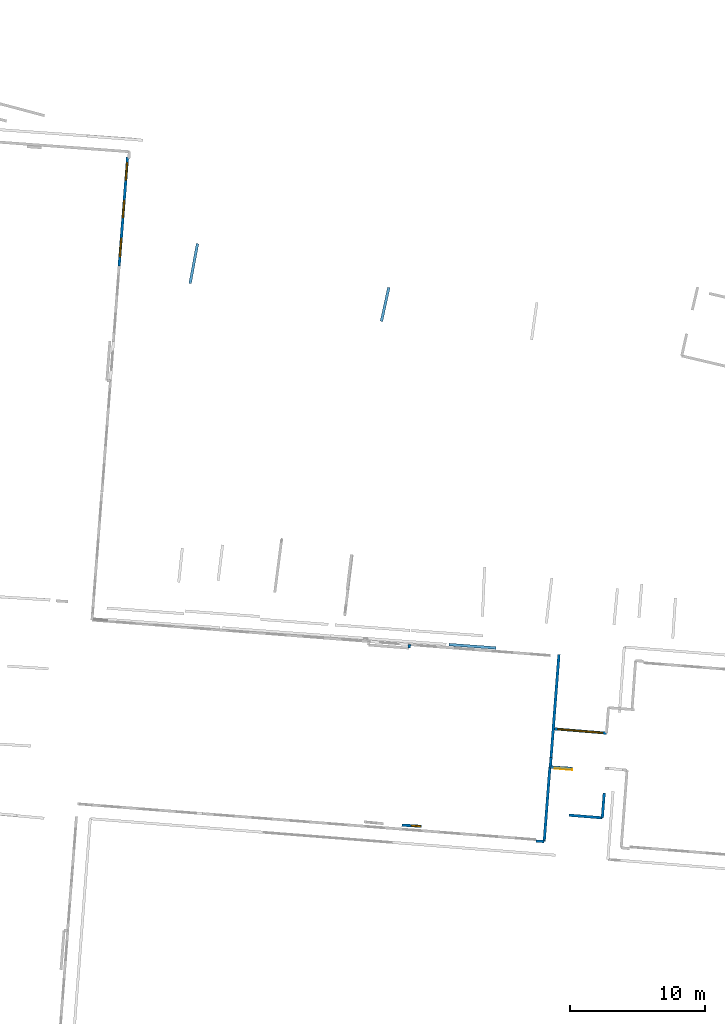
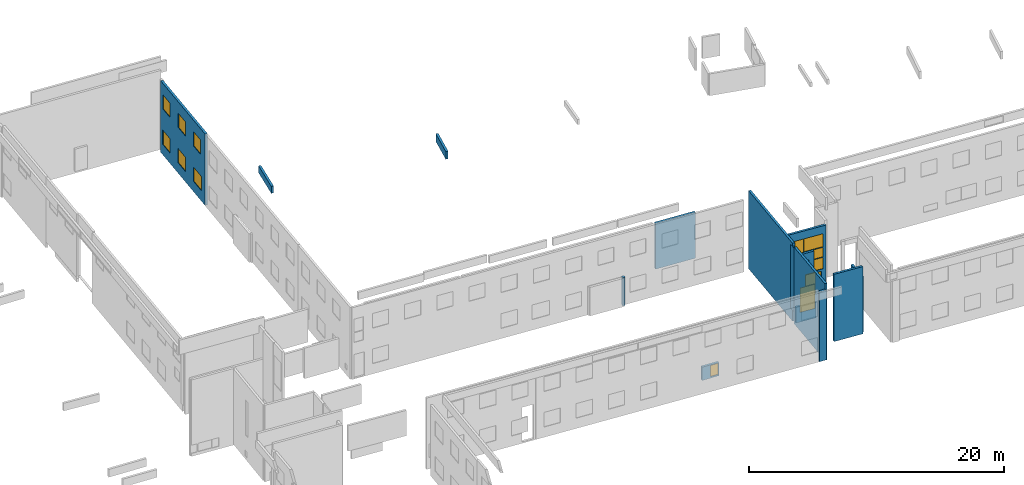
# One storey, part 15 of 27: 15 walls, 13 windows, 1 door, 15 openings.
"""IFC2X3 building model written with IfcOpenShell, lengths in metres."""

from ifc_helpers import new_model, entity, si_unit, converted_unit, derived_unit, direction, frame, frame_2d, origin, origin_2d_with_axis, place, context, subcontext, project, spatial, polyline, rectangle, outline, extrude, source, transform, mapped, material, layer, layer_set, layer_usage, type_object, type_shapes, element, fill, save


model = new_model("IFC2X3")

# Units and contexts
model_context = context("Model", 3, precision=1e-05, world=origin(), true_north=direction((0.0, 1.0)))
body_context = subcontext(model_context, "Body", "Model", "MODEL_VIEW")
ifc_project = project(units=[si_unit("LENGTHUNIT", "METRE"), si_unit("AREAUNIT", "SQUARE_METRE"), si_unit("VOLUMEUNIT", "CUBIC_METRE"), converted_unit("PLANEANGLEUNIT", "DEGREE", entity("IfcRatioMeasure", 0.0174532925199433), si_unit("PLANEANGLEUNIT", "RADIAN"), dimensions=[0, 0, 0, 0, 0, 0, 0]), si_unit("MASSUNIT", "GRAM", prefix="KILO"), derived_unit("MASSDENSITYUNIT", [(si_unit("MASSUNIT", "GRAM", prefix="KILO"), 1), (si_unit("LENGTHUNIT", "METRE"), -3)]), derived_unit("MOMENTOFINERTIAUNIT", [(si_unit("LENGTHUNIT", "METRE"), 4)]), si_unit("TIMEUNIT", "SECOND"), si_unit("FREQUENCYUNIT", "HERTZ"), si_unit("THERMODYNAMICTEMPERATUREUNIT", "DEGREE_CELSIUS"), derived_unit("THERMALTRANSMITTANCEUNIT", [(si_unit("MASSUNIT", "GRAM", prefix="KILO"), 1), (si_unit("THERMODYNAMICTEMPERATUREUNIT", "KELVIN"), -1), (si_unit("TIMEUNIT", "SECOND"), -3)]), derived_unit("VOLUMETRICFLOWRATEUNIT", [(si_unit("LENGTHUNIT", "METRE"), 3), (si_unit("TIMEUNIT", "SECOND"), -1)]), si_unit("ELECTRICCURRENTUNIT", "AMPERE"), si_unit("ELECTRICVOLTAGEUNIT", "VOLT"), si_unit("POWERUNIT", "WATT"), si_unit("FORCEUNIT", "NEWTON", prefix="KILO"), si_unit("ILLUMINANCEUNIT", "LUX"), si_unit("LUMINOUSFLUXUNIT", "LUMEN"), si_unit("LUMINOUSINTENSITYUNIT", "CANDELA"), derived_unit("USERDEFINED", [(si_unit("MASSUNIT", "GRAM", prefix="KILO"), -1), (si_unit("LENGTHUNIT", "METRE"), -2), (si_unit("TIMEUNIT", "SECOND"), 3), (si_unit("LUMINOUSFLUXUNIT", "LUMEN"), 1)]), derived_unit("LINEARVELOCITYUNIT", [(si_unit("LENGTHUNIT", "METRE"), 1), (si_unit("TIMEUNIT", "SECOND"), -1)]), si_unit("PRESSUREUNIT", "PASCAL"), derived_unit("USERDEFINED", [(si_unit("LENGTHUNIT", "METRE"), -2), (si_unit("MASSUNIT", "GRAM", prefix="KILO"), 1), (si_unit("TIMEUNIT", "SECOND"), -2)]), derived_unit("LINEARFORCEUNIT", [(si_unit("MASSUNIT", "GRAM", prefix="KILO"), 1), (si_unit("LENGTHUNIT", "METRE"), 1), (si_unit("TIMEUNIT", "SECOND"), -2), (si_unit("LENGTHUNIT", "METRE"), -1)]), derived_unit("PLANARFORCEUNIT", [(si_unit("MASSUNIT", "GRAM", prefix="KILO"), 1), (si_unit("LENGTHUNIT", "METRE"), 1), (si_unit("TIMEUNIT", "SECOND"), -2), (si_unit("LENGTHUNIT", "METRE"), -2)])], contexts=[model_context])

# Site, building, storey
placement_1 = place(None, origin())
site = spatial("IfcSite", under=ifc_project, at=placement_1, CompositionType="ELEMENT")
building = spatial("IfcBuilding", under=site, at=placement_1, CompositionType="ELEMENT")
storey_placement = place(placement_1, frame((0.0, 0.0, -61.043098449707)))
storey = spatial("IfcBuildingStorey", under=building, at=storey_placement, Name="level_-61.043098", CompositionType="ELEMENT", Elevation=-61.043098449707)

# Walls
ifc_material_1 = material(Name="Default wall")
ifc_layer = layer(ifc_material_1, 0.2)
ifc_layer_set = layer_set([ifc_layer], Name="wall_thickness_0.2000")
ifc_layer_usage = layer_usage(ifc_layer_set, "AXIS2", "POSITIVE", -0.1)
wall_type = type_object("IfcWallType", Name="wall_thickness_0.2000", PredefinedType="STANDARD", material=ifc_layer_set)
placement_2 = place(placement_1, frame((0.0, 0.0, -60.9578857421875)))
wall_1_placement = place(placement_2, frame((-37.0200372301927, -16.0524016754655, 0.0), z_axis=(0.0, 0.0, 1.0), x_axis=(-0.998600389394532, 0.0528891510717408, 0.0)))
element("IfcWallStandardCase", 1, at=wall_1_placement, inside=storey, type_object=wall_type, material=ifc_layer_usage, Name="Wall:152", ObjectType="Wall", context=body_context, shape_type="SweptSolid", body=[
    extrude(outline(polyline([(0.622197280445608, -0.1), (0.622197280445608, 0.1), (0.0, 0.1), (0.0, -0.1), (0.622197280445608, -0.1)])), origin(), (0.0, 0.0, 1.0), 6.67697906494141),
])
placement_3 = place(placement_1, frame((0.0, 0.0, -60.9578857421875)))
wall_2_placement = place(placement_3, frame((-63.2678405746218, 25.3179473888967, 0.0), z_axis=(0.0, 0.0, 1.0), x_axis=(0.183105225783561, 0.983093320235038, 0.0)))
element("IfcWallStandardCase", 2, at=wall_2_placement, inside=storey, type_object=wall_type, material=ifc_layer_usage, Name="Wall:195", ObjectType="Wall", context=body_context, shape_type="SweptSolid", body=[
    extrude(outline(polyline([(3.00025398109914, -0.1), (3.00025398109914, 0.1), (0.0, 0.1), (0.0, -0.1), (3.00025398109914, -0.1)])), origin(), (0.0, 0.0, 1.0), 0.661750793457031),
])
wall_3_placement = place(storey_placement, frame((-47.027272995632, -1.71549155766349, 0.0), z_axis=(0.0, 0.0, 1.0), x_axis=(0.0876257353755917, 0.996153467343204, 0.0)))
element("IfcWallStandardCase", 3, at=wall_3_placement, inside=storey, type_object=wall_type, material=ifc_layer_usage, Name="Wall:417", ObjectType="Wall", context=body_context, shape_type="SweptSolid", body=[
    extrude(outline(polyline([(0.26298879071159, -0.1), (0.26298879071159, 0.1), (0.0, 0.1), (0.0, -0.1), (0.26298879071159, -0.1)])), origin(), (0.0, 0.0, 1.0), 2.72571182250977),
])
placement_4 = place(placement_1, frame((0.0, 0.0, -59.9867630004883)))
wall_4_placement = place(placement_4, frame((-36.5148844694939, -9.81366283017277, 0.0), z_axis=(0.0, 0.0, 1.0), x_axis=(-0.0738247869205139, -0.997271227317895, 0.0)))
element("IfcWallStandardCase", 4, at=wall_4_placement, inside=storey, type_object=wall_type, material=ifc_layer_usage, Name="Wall:574", ObjectType="Wall", context=body_context, shape_type="SweptSolid", body=[
    extrude(outline(polyline([(0.717573367123586, -0.1), (0.717573367123586, 0.1), (0.0, 0.1), (0.0, -0.1), (0.717573367123586, -0.1)])), origin(), (0.0, 0.0, 1.0), 6.1148567199707),
])
placement_5 = place(placement_1, frame((0.0, 0.0, -60.9578857421875)))
wall_5_placement = place(placement_5, frame((-32.5704525703659, -12.4499416985043, 0.0), z_axis=(0.0, 0.0, 1.0), x_axis=(-0.0771292254040907, -0.997021104384739, 0.0)))
element("IfcWallStandardCase", 5, at=wall_5_placement, inside=storey, type_object=wall_type, material=ifc_layer_usage, Name="Wall:581", ObjectType="Wall", context=body_context, shape_type="SweptSolid", body=[
    extrude(outline(polyline([(1.85330962665053, -0.1), (1.85330962665053, 0.1), (0.0, 0.1), (0.0, -0.1), (1.85330962665053, -0.1)])), origin(), (0.0, 0.0, 1.0), 5.34588623046875),
])

# Wall, opening, window
placement_6 = place(placement_1, frame((0.0, 0.0, -59.9867630004883)))
wall_6_placement = place(placement_6, frame((-46.120380331813, -14.9260019400806, 0.0), z_axis=(0.0, 0.0, 1.0), x_axis=(-0.998140237205835, 0.0609595511030088, 0.0)))
wall_6 = element("IfcWallStandardCase", 6, at=wall_6_placement, inside=storey, type_object=wall_type, material=ifc_layer_usage, Name="Wall:673", ObjectType="Wall", context=body_context, shape_type="SweptSolid", body=[
    extrude(outline(polyline([(1.45858802446844, -0.1), (1.45858802446844, 0.1), (0.0, 0.1), (0.0, -0.1), (1.45858802446844, -0.1)])), origin(), (0.0, 0.0, 1.0), 1.27852630615234),
])
opening_1_placement = place(wall_6_placement, frame((0.0500006700359802, -0.1, 0.138454437255859)))
opening_1 = element("IfcOpeningElement", 7, at=opening_1_placement, cuts=wall_6, Name="Opening : 700 x 1075 : 70", ObjectType="Opening", context=body_context, shape_type="SweptSolid", body=[
    extrude(rectangle(XDim=0.7, YDim=1.075, at=frame_2d((0.5375, 0.35), x_axis=(0.0, 1.0))), frame((0.0, 0.0, 0.0), z_axis=(0.0, 1.0, 0.0), x_axis=(0.0, 0.0, 1.0)), (0.0, 0.0, 1.0), 0.2),
])
ifc_material_2 = material(Name="Window Default")
window_style_1 = type_object("IfcWindowStyle", Name="Window : 700 x 1075mm", ConstructionType="NOTDEFINED", OperationType="NOTDEFINED", ParameterTakesPrecedence=False, Sizeable=False, material=ifc_material_2)
shared_shape_1 = source(origin(), body_context, "Body", "SweptSolid", [
    extrude(rectangle(XDim=0.1, YDim=0.7, at=origin_2d_with_axis()), frame((0.35, 0.1, 0.0), z_axis=(0.0, 0.0, 1.0), x_axis=(0.0, 1.0, 0.0)), (0.0, 0.0, 1.0), 1.075),
])
type_shapes(window_style_1, [shared_shape_1])
window_1_placement = place(opening_1_placement, origin())
window_1 = element("IfcWindow", 8, at=window_1_placement, inside=storey, type_object=window_style_1, Name="Window : 700 x 1075mm : 62", ObjectType="Window : 700 x 1075mm", OverallHeight=1.075, OverallWidth=0.7, context=body_context, shape_type="MappedRepresentation", body=[
    mapped(shared_shape_1, transform((0.0, 0.0, 0.0), scale=1.0)),
])
fill(opening_1, window_1)

# Walls
wall_7_placement = place(storey_placement, frame((-32.7133952443243, -14.2977281924001, 0.0), z_axis=(0.0, 0.0, 1.0), x_axis=(-0.996860150969085, 0.0791823175329724, 0.0)))
element("IfcWallStandardCase", 9, at=wall_7_placement, inside=storey, type_object=wall_type, material=ifc_layer_usage, Name="Wall:1039", ObjectType="Wall", context=body_context, shape_type="SweptSolid", body=[
    extrude(outline(polyline([(2.48715269829612, -0.1), (2.48715269829612, 0.1), (0.0, 0.1), (0.0, -0.1), (2.48715269829612, -0.1)])), origin(), (0.0, 0.0, 1.0), 6.44229888916016),
])
wall_8_placement = place(storey_placement, frame((-36.5989793655519, -10.5185171790629, 0.0), z_axis=(0.0, 0.0, 1.0), x_axis=(-0.0758680967857905, -0.997117862587017, 0.0)))
element("IfcWallStandardCase", 10, at=wall_8_placement, inside=storey, type_object=wall_type, material=ifc_layer_usage, Name="Wall:1173", ObjectType="Wall", context=body_context, shape_type="SweptSolid", body=[
    extrude(outline(polyline([(5.54987765112908, -0.1), (5.54987765112908, 0.1), (0.0, 0.1), (0.0, -0.1), (5.54987765112908, -0.1)])), origin(), (0.0, 0.0, 1.0), 7.32660675048828),
])

# Wall, opening, door
placement_7 = place(placement_1, frame((0.0, 0.0, -60.9578857421875)))
wall_9_placement = place(placement_7, frame((-34.8802351490061, -10.6662097816332, 0.0), z_axis=(0.0, 0.0, 1.0), x_axis=(-0.9963282509121, 0.0856155151502107, 0.0)))
wall_9 = element("IfcWallStandardCase", 11, at=wall_9_placement, inside=storey, type_object=wall_type, material=ifc_layer_usage, Name="Wall:1256", ObjectType="Wall", context=body_context, shape_type="SweptSolid", body=[
    extrude(outline(polyline([(1.72508024712668, -0.1), (1.72508024712668, 0.1), (0.0, 0.1), (0.0, -0.1), (1.72508024712668, -0.1)])), origin(), (0.0, 0.0, 1.0), 1.51040649414062),
])
opening_2_placement = place(wall_9_placement, frame((0.059996572224372, -0.1, 0.928901672363281)))
opening_2 = element("IfcOpeningElement", 12, at=opening_2_placement, cuts=wall_9, Name="Opening : 1290 x 2325 : 172", ObjectType="Opening", context=body_context, shape_type="SweptSolid", body=[
    extrude(rectangle(XDim=1.29, YDim=2.325, at=frame_2d((1.1625, 0.645), x_axis=(0.0, 1.0))), frame((0.0, 0.0, 0.0), z_axis=(0.0, 1.0, 0.0), x_axis=(0.0, 0.0, 1.0)), (0.0, 0.0, 1.0), 0.2),
])
ifc_material_3 = material(Name="Door Panel")
door_style = type_object("IfcDoorStyle", Name="Door : 1290 x 2325mm", ConstructionType="NOTDEFINED", OperationType="SINGLE_SWING_RIGHT", ParameterTakesPrecedence=False, Sizeable=False, material=ifc_material_3)
shared_shape_2 = source(origin(), body_context, "Body", "SweptSolid", [
    extrude(rectangle(XDim=0.05, YDim=1.29, at=origin_2d_with_axis()), frame((0.645, 0.175, 0.0), z_axis=(0.0, 0.0, 1.0), x_axis=(0.0, 1.0, 0.0)), (0.0, 0.0, 1.0), 2.325),
])
type_shapes(door_style, [shared_shape_2])
door_placement = place(opening_2_placement, origin())
door = element("IfcDoor", 13, at=door_placement, inside=storey, type_object=door_style, Name="Door : 1290 x 2325mm : 6", ObjectType="Door : 1290 x 2325mm", OverallHeight=2.325, OverallWidth=1.29, context=body_context, shape_type="MappedRepresentation", body=[
    mapped(shared_shape_2, transform((0.0, 0.0, 0.0), scale=1.0)),
])
fill(opening_2, door)

# Wall, openings, windows
wall_10_placement = place(storey_placement, frame((-32.4030801710621, -8.02005382141887, 0.0), z_axis=(0.0, 0.0, 1.0), x_axis=(-0.996609152140908, 0.0822812121263409, 0.0)))
wall_10 = element("IfcWallStandardCase", 14, at=wall_10_placement, inside=storey, type_object=wall_type, material=ifc_layer_usage, Name="Wall:1337", ObjectType="Wall", context=body_context, shape_type="SweptSolid", body=[
    extrude(outline(polyline([(3.95944026383871, -0.1), (3.95944026383871, 0.1), (0.0, 0.1), (0.0, -0.1), (3.95944026383871, -0.1)])), origin(), (0.0, 0.0, 1.0), 6.5118293762207),
])
opening_3_placement = place(wall_10_placement, frame((0.274046374124539, -0.1, 4.48965454101562)))
opening_3 = element("IfcOpeningElement", 15, at=opening_3_placement, cuts=wall_10, Name="Opening : 1650 x 1265 : 203", ObjectType="Opening", context=body_context, shape_type="SweptSolid", body=[
    extrude(rectangle(XDim=1.65, YDim=1.265, at=frame_2d((0.6325, 0.825), x_axis=(0.0, 1.0))), frame((0.0, 0.0, 0.0), z_axis=(0.0, 1.0, 0.0), x_axis=(0.0, 0.0, 1.0)), (0.0, 0.0, 1.0), 0.2),
])
opening_4_placement = place(wall_10_placement, frame((1.96404582123105, -0.1, 2.38465118408203)))
opening_4 = element("IfcOpeningElement", 16, at=opening_4_placement, cuts=wall_10, Name="Opening : 1655 x 3370 : 204", ObjectType="Opening", context=body_context, shape_type="SweptSolid", body=[
    extrude(rectangle(XDim=1.655, YDim=3.37, at=frame_2d((1.685, 0.8275), x_axis=(0.0, 1.0))), frame((0.0, 0.0, 0.0), z_axis=(0.0, 1.0, 0.0), x_axis=(0.0, 0.0, 1.0)), (0.0, 0.0, 1.0), 0.2),
])
opening_5_placement = place(wall_10_placement, frame((0.274046374124539, -0.1, 3.5196533203125)))
opening_5 = element("IfcOpeningElement", 17, at=opening_5_placement, cuts=wall_10, Name="Opening : 1645 x 935 : 205", ObjectType="Opening", context=body_context, shape_type="SweptSolid", body=[
    extrude(rectangle(XDim=1.645, YDim=0.935, at=frame_2d((0.4675, 0.8225), x_axis=(0.0, 1.0))), frame((0.0, 0.0, 0.0), z_axis=(0.0, 1.0, 0.0), x_axis=(0.0, 0.0, 1.0)), (0.0, 0.0, 1.0), 0.2),
])
opening_6_placement = place(wall_10_placement, frame((0.269047373866643, -0.1, 2.3946533203125)))
opening_6 = element("IfcOpeningElement", 18, at=opening_6_placement, cuts=wall_10, Name="Opening : 1650 x 1100 : 206", ObjectType="Opening", context=body_context, shape_type="SweptSolid", body=[
    extrude(rectangle(XDim=1.65, YDim=1.1, at=frame_2d((0.55, 0.825), x_axis=(0.0, 1.0))), frame((0.0, 0.0, 0.0), z_axis=(0.0, 1.0, 0.0), x_axis=(0.0, 0.0, 1.0)), (0.0, 0.0, 1.0), 0.2),
])
opening_7_placement = place(wall_10_placement, frame((0.424045305038958, -0.1, 0.164653778076172)))
opening_7 = element("IfcOpeningElement", 19, at=opening_7_placement, cuts=wall_10, Name="Opening : 340 x 2040 : 207", ObjectType="Opening", context=body_context, shape_type="SweptSolid", body=[
    extrude(rectangle(XDim=0.34, YDim=2.04, at=frame_2d((1.02, 0.17), x_axis=(0.0, 1.0))), frame((0.0, 0.0, 0.0), z_axis=(0.0, 1.0, 0.0), x_axis=(0.0, 0.0, 1.0)), (0.0, 0.0, 1.0), 0.2),
])
opening_8_placement = place(wall_10_placement, frame((0.89904462412663, -0.1, 0.159652709960938)))
opening_8 = element("IfcOpeningElement", 20, at=opening_8_placement, cuts=wall_10, Name="Opening : 875 x 2045 : 208", ObjectType="Opening", context=body_context, shape_type="SweptSolid", body=[
    extrude(rectangle(XDim=0.875, YDim=2.045, at=frame_2d((1.0225, 0.4375), x_axis=(0.0, 1.0))), frame((0.0, 0.0, 0.0), z_axis=(0.0, 1.0, 0.0), x_axis=(0.0, 0.0, 1.0)), (0.0, 0.0, 1.0), 0.2),
])
window_style_2 = type_object("IfcWindowStyle", Name="Window : 1650 x 1265mm", ConstructionType="NOTDEFINED", OperationType="NOTDEFINED", ParameterTakesPrecedence=False, Sizeable=False, material=ifc_material_2)
shared_shape_3 = source(origin(), body_context, "Body", "SweptSolid", [
    extrude(rectangle(XDim=0.1, YDim=1.65, at=origin_2d_with_axis()), frame((0.825, 0.1, 0.0), z_axis=(0.0, 0.0, 1.0), x_axis=(0.0, 1.0, 0.0)), (0.0, 0.0, 1.0), 1.265),
])
type_shapes(window_style_2, [shared_shape_3])
window_2_placement = place(opening_3_placement, origin())
window_2 = element("IfcWindow", 21, at=window_2_placement, inside=storey, type_object=window_style_2, Name="Window : 1650 x 1265mm : 186", ObjectType="Window : 1650 x 1265mm", OverallHeight=1.265, OverallWidth=1.65, context=body_context, shape_type="MappedRepresentation", body=[
    mapped(shared_shape_3, transform((0.0, 0.0, 0.0), scale=1.0)),
])
fill(opening_3, window_2)
window_style_3 = type_object("IfcWindowStyle", Name="Window : 1655 x 3370mm", ConstructionType="NOTDEFINED", OperationType="NOTDEFINED", ParameterTakesPrecedence=False, Sizeable=False, material=ifc_material_2)
shared_shape_4 = source(origin(), body_context, "Body", "SweptSolid", [
    extrude(rectangle(XDim=0.1, YDim=1.655, at=origin_2d_with_axis()), frame((0.8275, 0.1, 0.0), z_axis=(0.0, 0.0, 1.0), x_axis=(0.0, 1.0, 0.0)), (0.0, 0.0, 1.0), 3.37),
])
type_shapes(window_style_3, [shared_shape_4])
window_3_placement = place(opening_4_placement, origin())
window_3 = element("IfcWindow", 22, at=window_3_placement, inside=storey, type_object=window_style_3, Name="Window : 1655 x 3370mm : 187", ObjectType="Window : 1655 x 3370mm", OverallHeight=3.37, OverallWidth=1.655, context=body_context, shape_type="MappedRepresentation", body=[
    mapped(shared_shape_4, transform((0.0, 0.0, 0.0), scale=1.0)),
])
fill(opening_4, window_3)
window_style_4 = type_object("IfcWindowStyle", Name="Window : 1645 x 935mm", ConstructionType="NOTDEFINED", OperationType="NOTDEFINED", ParameterTakesPrecedence=False, Sizeable=False, material=ifc_material_2)
shared_shape_5 = source(origin(), body_context, "Body", "SweptSolid", [
    extrude(rectangle(XDim=0.1, YDim=1.645, at=origin_2d_with_axis()), frame((0.8225, 0.1, 0.0), z_axis=(0.0, 0.0, 1.0), x_axis=(0.0, 1.0, 0.0)), (0.0, 0.0, 1.0), 0.935),
])
type_shapes(window_style_4, [shared_shape_5])
window_4_placement = place(opening_5_placement, origin())
window_4 = element("IfcWindow", 23, at=window_4_placement, inside=storey, type_object=window_style_4, Name="Window : 1645 x 935mm : 188", ObjectType="Window : 1645 x 935mm", OverallHeight=0.935, OverallWidth=1.645, context=body_context, shape_type="MappedRepresentation", body=[
    mapped(shared_shape_5, transform((0.0, 0.0, 0.0), scale=1.0)),
])
fill(opening_5, window_4)
window_style_5 = type_object("IfcWindowStyle", Name="Window : 1650 x 1100mm", ConstructionType="NOTDEFINED", OperationType="NOTDEFINED", ParameterTakesPrecedence=False, Sizeable=False, material=ifc_material_2)
shared_shape_6 = source(origin(), body_context, "Body", "SweptSolid", [
    extrude(rectangle(XDim=0.1, YDim=1.65, at=origin_2d_with_axis()), frame((0.825, 0.1, 0.0), z_axis=(0.0, 0.0, 1.0), x_axis=(0.0, 1.0, 0.0)), (0.0, 0.0, 1.0), 1.1),
])
type_shapes(window_style_5, [shared_shape_6])
window_5_placement = place(opening_6_placement, origin())
window_5 = element("IfcWindow", 24, at=window_5_placement, inside=storey, type_object=window_style_5, Name="Window : 1650 x 1100mm : 189", ObjectType="Window : 1650 x 1100mm", OverallHeight=1.1, OverallWidth=1.65, context=body_context, shape_type="MappedRepresentation", body=[
    mapped(shared_shape_6, transform((0.0, 0.0, 0.0), scale=1.0)),
])
fill(opening_6, window_5)
window_style_6 = type_object("IfcWindowStyle", Name="Window : 340 x 2040mm", ConstructionType="NOTDEFINED", OperationType="NOTDEFINED", ParameterTakesPrecedence=False, Sizeable=False, material=ifc_material_2)
shared_shape_7 = source(origin(), body_context, "Body", "SweptSolid", [
    extrude(rectangle(XDim=0.1, YDim=0.34, at=origin_2d_with_axis()), frame((0.17, 0.1, 0.0), z_axis=(0.0, 0.0, 1.0), x_axis=(0.0, 1.0, 0.0)), (0.0, 0.0, 1.0), 2.04),
])
type_shapes(window_style_6, [shared_shape_7])
window_6_placement = place(opening_7_placement, origin())
window_6 = element("IfcWindow", 25, at=window_6_placement, inside=storey, type_object=window_style_6, Name="Window : 340 x 2040mm : 190", ObjectType="Window : 340 x 2040mm", OverallHeight=2.04, OverallWidth=0.34, context=body_context, shape_type="MappedRepresentation", body=[
    mapped(shared_shape_7, transform((0.0, 0.0, 0.0), scale=1.0)),
])
fill(opening_7, window_6)
window_style_7 = type_object("IfcWindowStyle", Name="Window : 875 x 2045mm", ConstructionType="NOTDEFINED", OperationType="NOTDEFINED", ParameterTakesPrecedence=False, Sizeable=False, material=ifc_material_2)
shared_shape_8 = source(origin(), body_context, "Body", "SweptSolid", [
    extrude(rectangle(XDim=0.1, YDim=0.875, at=origin_2d_with_axis()), frame((0.4375, 0.1, 0.0), z_axis=(0.0, 0.0, 1.0), x_axis=(0.0, 1.0, 0.0)), (0.0, 0.0, 1.0), 2.045),
])
type_shapes(window_style_7, [shared_shape_8])
window_7_placement = place(opening_8_placement, origin())
window_7 = element("IfcWindow", 26, at=window_7_placement, inside=storey, type_object=window_style_7, Name="Window : 875 x 2045mm : 191", ObjectType="Window : 875 x 2045mm", OverallHeight=2.045, OverallWidth=0.875, context=body_context, shape_type="MappedRepresentation", body=[
    mapped(shared_shape_8, transform((0.0, 0.0, 0.0), scale=1.0)),
])
fill(opening_8, window_7)

# Walls
placement_8 = place(placement_1, frame((0.0, 0.0, -58.6692237854004)))
wall_11_placement = place(placement_8, frame((-44.0704143280616, -1.45279970064969, 0.0), z_axis=(0.0, 0.0, 1.0), x_axis=(0.997320641977179, -0.0731542007421811, 0.0)))
element("IfcWallStandardCase", 27, at=wall_11_placement, inside=storey, type_object=wall_type, material=ifc_layer_usage, Name="Wall:1430", ObjectType="Wall", context=body_context, shape_type="SweptSolid", body=[
    extrude(outline(polyline([(3.47500138563488, -0.1), (3.47500138563488, 0.1), (0.0, 0.1), (0.0, -0.1), (3.47500138563488, -0.1)])), origin(), (0.0, 0.0, 1.0), 4.3883171081543),
])
wall_12_placement = place(storey_placement, frame((-35.9275419658002, -2.20070825959961, 0.0), z_axis=(0.0, 0.0, 1.0), x_axis=(-0.0765101996187178, -0.997068798706641, 0.0)))
element("IfcWallStandardCase", 28, at=wall_12_placement, inside=storey, type_object=wall_type, material=ifc_layer_usage, Name="Wall:1591", ObjectType="Wall", context=body_context, shape_type="SweptSolid", body=[
    extrude(outline(polyline([(7.97539383834117, -0.1), (7.97539383834117, 0.1), (0.0, 0.1), (0.0, -0.1), (7.97539383834117, -0.1)])), origin(), (0.0, 0.0, 1.0), 7.4647102355957),
])
placement_9 = place(placement_1, frame((0.0, 0.0, -60.9578857421875)))
wall_13_placement = place(placement_9, frame((-49.0848434467702, 22.5056424875311, 0.0), z_axis=(0.0, 0.0, 1.0), x_axis=(0.212129806137661, 0.977241497966597, 0.0)))
element("IfcWallStandardCase", 29, at=wall_13_placement, inside=storey, type_object=wall_type, material=ifc_layer_usage, Name="Wall:1684", ObjectType="Wall", context=body_context, shape_type="SweptSolid", body=[
    extrude(outline(polyline([(2.57000020386452, -0.1), (2.57000020386452, 0.1), (0.0, 0.1), (0.0, -0.1), (2.57000020386452, -0.1)])), origin(), (0.0, 0.0, 1.0), 0.739894866943359),
])

# Wall, opening
placement_10 = place(placement_1, frame((0.0, 0.0, -59.5395584106445)))
wall_14_placement = place(placement_10, frame((-35.0101656493806, -10.6263727979115, 0.0), z_axis=(0.0, 0.0, 1.0), x_axis=(-0.998062938165299, 0.0622123095604904, 0.0)))
wall_14 = element("IfcWallStandardCase", 30, at=wall_14_placement, inside=storey, type_object=wall_type, material=ifc_layer_usage, Name="Wall:1846", ObjectType="Wall", context=body_context, shape_type="SweptSolid", body=[
    extrude(outline(polyline([(1.59256625306782, -0.1), (1.59256625306782, 0.1), (0.0, 0.1), (0.0, -0.1), (1.59256625306782, -0.1)])), origin(), (0.0, 0.0, 1.0), 5.0082893371582),
])
opening_9_placement = place(wall_14_placement, frame((0.429997760462984, -0.1, 0.0532913208007812)))
element("IfcOpeningElement", 31, at=opening_9_placement, cuts=wall_14, Name="Opening : 805 x 4245 : 284", ObjectType="Opening", context=body_context, shape_type="SweptSolid", body=[
    extrude(rectangle(XDim=0.805, YDim=4.245, at=frame_2d((2.1225, 0.4025), x_axis=(0.0, 1.0))), frame((0.0, 0.0, 0.0), z_axis=(0.0, 1.0, 0.0), x_axis=(0.0, 0.0, 1.0)), (0.0, 0.0, 1.0), 0.2),
])

# Wall, openings, windows
wall_15_placement = place(storey_placement, frame((-67.9032874621412, 34.6705275496588, 0.0), z_axis=(0.0, 0.0, 1.0), x_axis=(-0.0775823258634108, -0.996985949105414, 0.0)))
wall_15 = element("IfcWallStandardCase", 32, at=wall_15_placement, inside=storey, type_object=wall_type, material=ifc_layer_usage, Name="Wall:1871", ObjectType="Wall", context=body_context, shape_type="SweptSolid", body=[
    extrude(outline(polyline([(8.0949992493728, -0.1), (8.0949992493728, 0.1), (0.0, 0.1), (0.0, -0.1), (8.0949992493728, -0.1)])), origin(), (0.0, 0.0, 1.0), 6.83392333984375),
])
opening_10_placement = place(wall_15_placement, frame((3.21000007047297, -0.1, 4.38211059570312)))
opening_10 = element("IfcOpeningElement", 33, at=opening_10_placement, cuts=wall_15, Name="Opening : 1300 x 1365 : 285", ObjectType="Opening", context=body_context, shape_type="SweptSolid", body=[
    extrude(rectangle(XDim=1.3, YDim=1.365, at=frame_2d((0.6825, 0.65), x_axis=(0.0, 1.0))), frame((0.0, 0.0, 0.0), z_axis=(0.0, 1.0, 0.0), x_axis=(0.0, 0.0, 1.0)), (0.0, 0.0, 1.0), 0.2),
])
opening_11_placement = place(wall_15_placement, frame((0.40500234076263, -0.1, 4.39210891723633)))
opening_11 = element("IfcOpeningElement", 34, at=opening_11_placement, cuts=wall_15, Name="Opening : 1300 x 1365 : 286", ObjectType="Opening", context=body_context, shape_type="SweptSolid", body=[
    extrude(rectangle(XDim=1.3, YDim=1.365, at=frame_2d((0.6825, 0.65), x_axis=(0.0, 1.0))), frame((0.0, 0.0, 0.0), z_axis=(0.0, 1.0, 0.0), x_axis=(0.0, 0.0, 1.0)), (0.0, 0.0, 1.0), 0.2),
])
opening_12_placement = place(wall_15_placement, frame((6.0100000424188, -0.1, 4.36711120605469)))
opening_12 = element("IfcOpeningElement", 35, at=opening_12_placement, cuts=wall_15, Name="Opening : 1295 x 1380 : 287", ObjectType="Opening", context=body_context, shape_type="SweptSolid", body=[
    extrude(rectangle(XDim=1.295, YDim=1.38, at=frame_2d((0.69, 0.6475), x_axis=(0.0, 1.0))), frame((0.0, 0.0, 0.0), z_axis=(0.0, 1.0, 0.0), x_axis=(0.0, 0.0, 1.0)), (0.0, 0.0, 1.0), 0.2),
])
opening_13_placement = place(wall_15_placement, frame((0.389999433588876, -0.1, 0.982109069824219)))
opening_13 = element("IfcOpeningElement", 36, at=opening_13_placement, cuts=wall_15, Name="Opening : 1305 x 1370 : 288", ObjectType="Opening", context=body_context, shape_type="SweptSolid", body=[
    extrude(rectangle(XDim=1.305, YDim=1.37, at=frame_2d((0.685, 0.6525), x_axis=(0.0, 1.0))), frame((0.0, 0.0, 0.0), z_axis=(0.0, 1.0, 0.0), x_axis=(0.0, 0.0, 1.0)), (0.0, 0.0, 1.0), 0.2),
])
opening_14_placement = place(wall_15_placement, frame((3.20000003395692, -0.1, 0.987110137939453)))
opening_14 = element("IfcOpeningElement", 37, at=opening_14_placement, cuts=wall_15, Name="Opening : 1305 x 1365 : 289", ObjectType="Opening", context=body_context, shape_type="SweptSolid", body=[
    extrude(rectangle(XDim=1.305, YDim=1.365, at=frame_2d((0.6825, 0.6525), x_axis=(0.0, 1.0))), frame((0.0, 0.0, 0.0), z_axis=(0.0, 1.0, 0.0), x_axis=(0.0, 0.0, 1.0)), (0.0, 0.0, 1.0), 0.2),
])
opening_15_placement = place(wall_15_placement, frame((6.0100000424188, -0.1, 0.982109069824219)))
opening_15 = element("IfcOpeningElement", 38, at=opening_15_placement, cuts=wall_15, Name="Opening : 1405 x 1365 : 290", ObjectType="Opening", context=body_context, shape_type="SweptSolid", body=[
    extrude(rectangle(XDim=1.405, YDim=1.365, at=frame_2d((0.6825, 0.7025), x_axis=(0.0, 1.0))), frame((0.0, 0.0, 0.0), z_axis=(0.0, 1.0, 0.0), x_axis=(0.0, 0.0, 1.0)), (0.0, 0.0, 1.0), 0.2),
])
window_style_8 = type_object("IfcWindowStyle", Name="Window : 1405 x 1365mm", ConstructionType="NOTDEFINED", OperationType="NOTDEFINED", ParameterTakesPrecedence=False, Sizeable=False, material=ifc_material_2)
shared_shape_9 = source(origin(), body_context, "Body", "SweptSolid", [
    extrude(rectangle(XDim=0.1, YDim=1.405, at=origin_2d_with_axis()), frame((0.7025, 0.1, 0.0), z_axis=(0.0, 0.0, 1.0), x_axis=(0.0, 1.0, 0.0)), (0.0, 0.0, 1.0), 1.365),
])
type_shapes(window_style_8, [shared_shape_9])
window_8_placement = place(opening_15_placement, origin())
window_8 = element("IfcWindow", 39, at=window_8_placement, inside=storey, type_object=window_style_8, Name="Window : 1405 x 1365mm : 271", ObjectType="Window : 1405 x 1365mm", OverallHeight=1.365, OverallWidth=1.405, context=body_context, shape_type="MappedRepresentation", body=[
    mapped(shared_shape_9, transform((0.0, 0.0, 0.0), scale=1.0)),
])
fill(opening_15, window_8)
window_style_9 = type_object("IfcWindowStyle", Name="Window : 1300 x 1365mm", ConstructionType="NOTDEFINED", OperationType="NOTDEFINED", ParameterTakesPrecedence=False, Sizeable=False, material=ifc_material_2)
shared_shape_10 = source(origin(), body_context, "Body", "SweptSolid", [
    extrude(rectangle(XDim=0.1, YDim=1.3, at=origin_2d_with_axis()), frame((0.65, 0.1, 0.0), z_axis=(0.0, 0.0, 1.0), x_axis=(0.0, 1.0, 0.0)), (0.0, 0.0, 1.0), 1.365),
])
type_shapes(window_style_9, [shared_shape_10])
window_9_placement = place(opening_10_placement, origin())
window_9 = element("IfcWindow", 40, at=window_9_placement, inside=storey, type_object=window_style_9, Name="Window : 1300 x 1365mm : 266", ObjectType="Window : 1300 x 1365mm", OverallHeight=1.365, OverallWidth=1.3, context=body_context, shape_type="MappedRepresentation", body=[
    mapped(shared_shape_10, transform((0.0, 0.0, 0.0), scale=1.0)),
])
fill(opening_10, window_9)
window_10_placement = place(opening_11_placement, origin())
window_10 = element("IfcWindow", 41, at=window_10_placement, inside=storey, type_object=window_style_9, Name="Window : 1300 x 1365mm : 267", ObjectType="Window : 1300 x 1365mm", OverallHeight=1.365, OverallWidth=1.3, context=body_context, shape_type="MappedRepresentation", body=[
    mapped(shared_shape_10, transform((0.0, 0.0, 0.0), scale=1.0)),
])
fill(opening_11, window_10)
window_style_10 = type_object("IfcWindowStyle", Name="Window : 1295 x 1380mm", ConstructionType="NOTDEFINED", OperationType="NOTDEFINED", ParameterTakesPrecedence=False, Sizeable=False, material=ifc_material_2)
shared_shape_11 = source(origin(), body_context, "Body", "SweptSolid", [
    extrude(rectangle(XDim=0.1, YDim=1.295, at=origin_2d_with_axis()), frame((0.6475, 0.1, 0.0), z_axis=(0.0, 0.0, 1.0), x_axis=(0.0, 1.0, 0.0)), (0.0, 0.0, 1.0), 1.38),
])
type_shapes(window_style_10, [shared_shape_11])
window_11_placement = place(opening_12_placement, origin())
window_11 = element("IfcWindow", 42, at=window_11_placement, inside=storey, type_object=window_style_10, Name="Window : 1295 x 1380mm : 268", ObjectType="Window : 1295 x 1380mm", OverallHeight=1.38, OverallWidth=1.295, context=body_context, shape_type="MappedRepresentation", body=[
    mapped(shared_shape_11, transform((0.0, 0.0, 0.0), scale=1.0)),
])
fill(opening_12, window_11)
window_style_11 = type_object("IfcWindowStyle", Name="Window : 1305 x 1370mm", ConstructionType="NOTDEFINED", OperationType="NOTDEFINED", ParameterTakesPrecedence=False, Sizeable=False, material=ifc_material_2)
shared_shape_12 = source(origin(), body_context, "Body", "SweptSolid", [
    extrude(rectangle(XDim=0.1, YDim=1.305, at=origin_2d_with_axis()), frame((0.6525, 0.1, 0.0), z_axis=(0.0, 0.0, 1.0), x_axis=(0.0, 1.0, 0.0)), (0.0, 0.0, 1.0), 1.37),
])
type_shapes(window_style_11, [shared_shape_12])
window_12_placement = place(opening_13_placement, origin())
window_12 = element("IfcWindow", 43, at=window_12_placement, inside=storey, type_object=window_style_11, Name="Window : 1305 x 1370mm : 269", ObjectType="Window : 1305 x 1370mm", OverallHeight=1.37, OverallWidth=1.305, context=body_context, shape_type="MappedRepresentation", body=[
    mapped(shared_shape_12, transform((0.0, 0.0, 0.0), scale=1.0)),
])
fill(opening_13, window_12)
window_style_12 = type_object("IfcWindowStyle", Name="Window : 1305 x 1365mm", ConstructionType="NOTDEFINED", OperationType="NOTDEFINED", ParameterTakesPrecedence=False, Sizeable=False, material=ifc_material_2)
shared_shape_13 = source(origin(), body_context, "Body", "SweptSolid", [
    extrude(rectangle(XDim=0.1, YDim=1.305, at=origin_2d_with_axis()), frame((0.6525, 0.1, 0.0), z_axis=(0.0, 0.0, 1.0), x_axis=(0.0, 1.0, 0.0)), (0.0, 0.0, 1.0), 1.365),
])
type_shapes(window_style_12, [shared_shape_13])
window_13_placement = place(opening_14_placement, origin())
window_13 = element("IfcWindow", 44, at=window_13_placement, inside=storey, type_object=window_style_12, Name="Window : 1305 x 1365mm : 270", ObjectType="Window : 1305 x 1365mm", OverallHeight=1.365, OverallWidth=1.305, context=body_context, shape_type="MappedRepresentation", body=[
    mapped(shared_shape_13, transform((0.0, 0.0, 0.0), scale=1.0)),
])
fill(opening_14, window_13)

save(model, "model.ifc")
